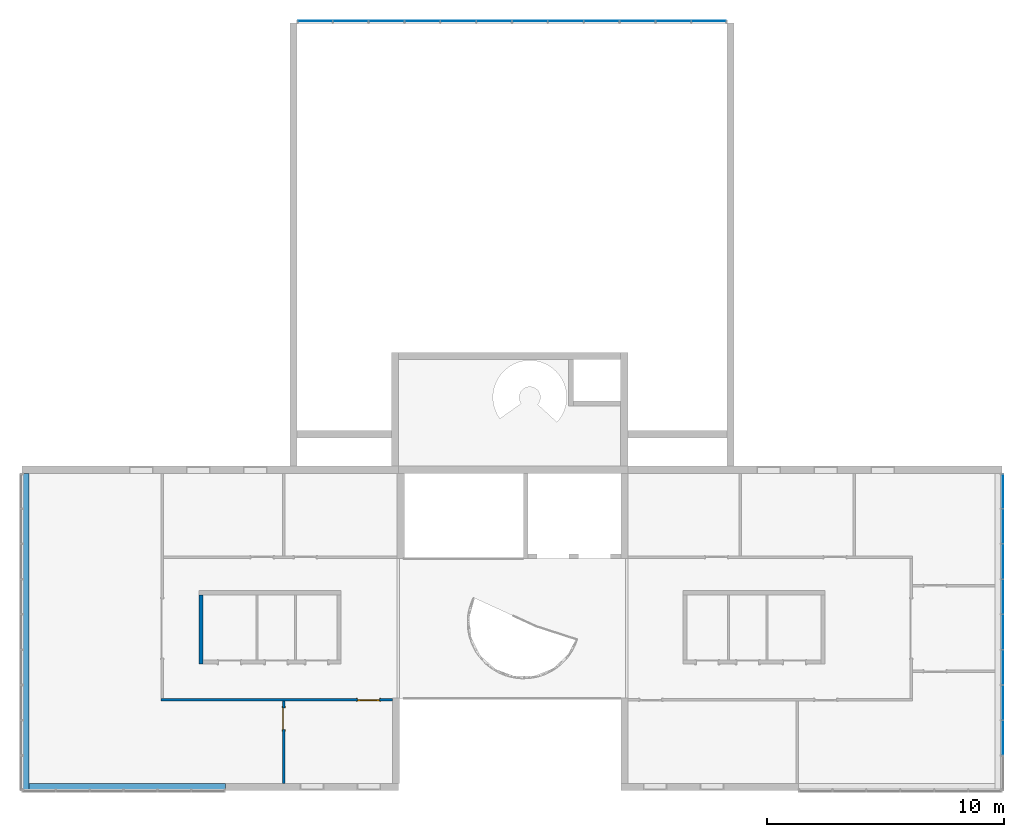
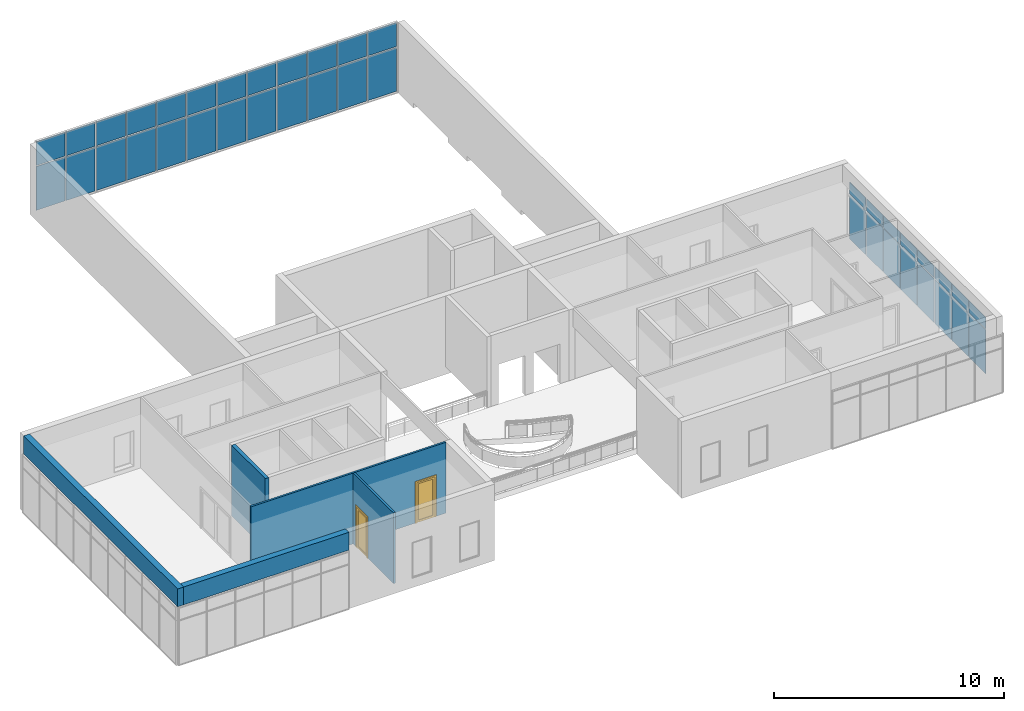
# One storey, part 9 of 13: 40 plates, 5 walls, 2 doors, 2 openings, 2 elements without a shape of their own.
"""IFC2X3 building model written with IfcOpenShell, lengths in millimetres."""

import ifcopenshell
import ifcopenshell.guid

model = None  # the IFC model being written
_history = None  # IfcOwnerHistory: only IFC2X3 demands one
_inside = {}  # id of a spatial element -> (the spatial element, [elements in it])
_under = {}  # id of a project, library or spatial element -> (it, [spatial elements below it])
_declared = {}  # id of a project -> (the project, [libraries it declares])
_typed = {}  # id of a type object -> (the type object, [elements of that type])
_made_of = {}  # id of a material, layer set ... -> (it, [elements and type objects made of it])


def new_model(schema):
    """Start an empty IFC model of exactly this schema.

    Asked for "IFC4X3", IfcOpenShell would pick the latest addendum, in which some entities
    have other attributes; the version numbers below select the first issue.
    IFC2X3 requires an IfcOwnerHistory on every rooted entity: one is made here for all.
    """
    global model, _history
    if schema == "IFC4X3":
        model = ifcopenshell.file(schema_version=(4, 3, 0, 0))
    else:
        model = ifcopenshell.file(schema=schema)
    _inside.clear()
    _under.clear()
    _declared.clear()
    _typed.clear()
    _made_of.clear()
    _history = None
    if model.schema == "IFC2X3":
        org = make("IfcOrganization", Name="unknown")
        user = make(
            "IfcPersonAndOrganization",
            ThePerson=make("IfcPerson", FamilyName="unknown"),
            TheOrganization=org,
        )
        app = make(
            "IfcApplication",
            ApplicationDeveloper=org,
            Version="unknown",
            ApplicationFullName="unknown",
            ApplicationIdentifier="unknown",
        )
        _history = make(
            "IfcOwnerHistory",
            OwningUser=user,
            OwningApplication=app,
            ChangeAction="ADDED",
            CreationDate=0,
        )
    return model


def make(cls, **values):
    """One entity of the class cls with the attributes given. An attribute that is None is left unset."""
    return model.create_entity(
        cls, **{name: value for name, value in values.items() if value is not None}
    )


def entity(cls, *values):
    """Any entity or typed value of the class cls, its attributes in the order of the schema. None: left unset."""
    e = model.create_entity(cls)
    for i, value in enumerate(values):
        if value is not None:
            e[i] = value
    return e


def rooted(cls, **values):
    """An entity with a GlobalId (a new one), such as an element, a storey or a relation."""
    return make(cls, GlobalId=ifcopenshell.guid.new(), OwnerHistory=_history, **values)


def si_unit(unit_type, name, prefix=None):
    """IfcSIUnit, for example si_unit("LENGTHUNIT", "METRE", prefix="MILLI")."""
    return make("IfcSIUnit", UnitType=unit_type, Prefix=prefix, Name=name)


def converted_unit(unit_type, name, factor, base, dimensions=None, offset=None):
    """IfcConversionBasedUnit, such as the inch: factor (a typed value) times the base unit."""
    return make(
        "IfcConversionBasedUnit"
        if offset is None
        else "IfcConversionBasedUnitWithOffset",
        ConversionOffset=offset,
        Dimensions=None
        if dimensions is None
        else entity("IfcDimensionalExponents", *dimensions),
        UnitType=unit_type,
        Name=name,
        ConversionFactor=make(
            "IfcMeasureWithUnit", ValueComponent=factor, UnitComponent=base
        ),
    )


def derived_unit(unit_type, elements):
    """IfcDerivedUnit: a product of units, each with its exponent."""
    return make(
        "IfcDerivedUnit",
        Elements=[
            make("IfcDerivedUnitElement", Unit=unit, Exponent=power)
            for unit, power in elements
        ],
        UnitType=unit_type,
    )


def assignment(units):
    """IfcUnitAssignment: the units of a project."""
    return None if units is None else make("IfcUnitAssignment", Units=units)


def point(xyz):
    """IfcCartesianPoint."""
    return None if xyz is None else make("IfcCartesianPoint", Coordinates=xyz)


def direction(xyz):
    """IfcDirection."""
    return None if xyz is None else make("IfcDirection", DirectionRatios=xyz)


def frame(location, z_axis=None, x_axis=None):
    """IfcAxis2Placement3D, a coordinate frame: its origin and axes. An axis left out is left unset."""
    return make(
        "IfcAxis2Placement3D",
        Location=point(location),
        Axis=direction(z_axis),
        RefDirection=direction(x_axis),
    )


def frame_2d(location, x_axis=None):
    """IfcAxis2Placement2D, a coordinate frame in the plane: its origin and x axis."""
    return make(
        "IfcAxis2Placement2D", Location=point(location), RefDirection=direction(x_axis)
    )


def origin():
    """The frame at (0, 0, 0) with its axes left unset."""
    return frame((0.0, 0.0, 0.0))


def origin_2d_with_axis():
    """The frame at (0, 0) in the plane with the x axis (1, 0) written out."""
    return frame_2d((0.0, 0.0), x_axis=(1.0, 0.0))


def place(relative_to, where):
    """IfcLocalPlacement: puts the frame where relative to a parent placement (None: the world)."""
    return make(
        "IfcLocalPlacement", PlacementRelTo=relative_to, RelativePlacement=where
    )


def context(
    kind, dimensions, precision=None, world=None, true_north=None, identifier=None
):
    """IfcGeometricRepresentationContext, for example the 3D "Model" context."""
    return make(
        "IfcGeometricRepresentationContext",
        ContextIdentifier=identifier,
        ContextType=kind,
        CoordinateSpaceDimension=dimensions,
        Precision=precision,
        WorldCoordinateSystem=world,
        TrueNorth=true_north,
    )


def subcontext(parent, identifier, kind, view, scale=None):
    """IfcGeometricRepresentationSubContext, for example "Body" below "Model"."""
    return make(
        "IfcGeometricRepresentationSubContext",
        ContextIdentifier=identifier,
        ContextType=kind,
        ParentContext=parent,
        TargetScale=scale,
        TargetView=view,
    )


def project(units=None, contexts=None):
    """IfcProject with its units and contexts."""
    return rooted(
        "IfcProject",
        Name="project",
        RepresentationContexts=contexts,
        UnitsInContext=assignment(units),
    )


def spatial(cls, under=None, at=None, **own):
    """A site, building, storey or space (cls), placed at a placement, below another one or the project."""
    s = rooted(cls, ObjectPlacement=at, **own)
    if under is not None:
        _under.setdefault(under.id(), (under, []))[1].append(s)
    return s


def polyline(points):
    """IfcPolyline through the points."""
    return make("IfcPolyline", Points=[point(p) for p in points])


def profile(cls, at=None, kind="AREA", **sizes):
    """A parametric profile (cls). Its sizes go by their IFC names, for example OverallWidth=200.0."""
    return make(cls, ProfileType=kind, Position=at, **sizes)


def rectangle(**sizes):
    """IfcRectangleProfileDef."""
    return profile("IfcRectangleProfileDef", **sizes)


def outline(outer, holes=None, kind="AREA"):
    """IfcArbitraryClosedProfileDef: a profile drawn as a closed curve; with holes, ...WithVoids."""
    if holes is None:
        return make("IfcArbitraryClosedProfileDef", ProfileType=kind, OuterCurve=outer)
    return make(
        "IfcArbitraryProfileDefWithVoids",
        ProfileType=kind,
        OuterCurve=outer,
        InnerCurves=holes,
    )


def extrude(swept, where, along, depth):
    """IfcExtrudedAreaSolid: the profile swept, set in the frame where, extruded along a direction by depth."""
    return make(
        "IfcExtrudedAreaSolid",
        SweptArea=swept,
        Position=where,
        ExtrudedDirection=direction(along),
        Depth=depth,
    )


def shape(context_of_items, identifier, shape_type, items):
    """IfcShapeRepresentation: the items that make up one representation, for example the "Body"."""
    return make(
        "IfcShapeRepresentation",
        ContextOfItems=context_of_items,
        RepresentationIdentifier=identifier,
        RepresentationType=shape_type,
        Items=items,
    )


def source(mapping_origin, context_of_items, identifier, shape_type, items):
    """IfcRepresentationMap: a shape defined once, which mapped items show again and again."""
    return make(
        "IfcRepresentationMap",
        MappingOrigin=mapping_origin,
        MappedRepresentation=shape(context_of_items, identifier, shape_type, items),
    )


def transform(
    local_origin,
    x_axis=None,
    y_axis=None,
    z_axis=None,
    scale=None,
    scale2=None,
    scale3=None,
    uniform=True,
):
    """IfcCartesianTransformationOperator3D, or its non-uniform kind. x_axis, y_axis, z_axis: its Axis1, 2, 3."""
    if uniform:
        return make(
            "IfcCartesianTransformationOperator3D",
            Axis1=direction(x_axis),
            Axis2=direction(y_axis),
            LocalOrigin=point(local_origin),
            Scale=scale,
            Axis3=direction(z_axis),
        )
    return make(
        "IfcCartesianTransformationOperator3DnonUniform",
        Axis1=direction(x_axis),
        Axis2=direction(y_axis),
        LocalOrigin=point(local_origin),
        Scale=scale,
        Axis3=direction(z_axis),
        Scale2=scale2,
        Scale3=scale3,
    )


def mapped(mapping_source, mapping_target):
    """IfcMappedItem: shows the shape of a source again, moved by a transform."""
    return make(
        "IfcMappedItem", MappingSource=mapping_source, MappingTarget=mapping_target
    )


def material(Name=None, Category=None):
    """IfcMaterial."""
    return make("IfcMaterial", Name=Name, Category=Category)


def material_list(materials):
    """IfcMaterialList."""
    return make("IfcMaterialList", Materials=materials)


def layer(
    of_material, thickness, ventilated=None, Name=None, Category=None, Priority=None
):
    """IfcMaterialLayer: one layer of a wall or slab, of a material (None: an air gap)."""
    return make(
        "IfcMaterialLayer",
        Material=of_material,
        LayerThickness=thickness,
        IsVentilated=ventilated,
        Name=Name,
        Category=Category,
        Priority=Priority,
    )


def layer_set(layers, Name=None):
    """IfcMaterialLayerSet."""
    return make("IfcMaterialLayerSet", MaterialLayers=layers, LayerSetName=Name)


def layer_usage(for_layer_set, set_direction, sense, offset, extent=None):
    """IfcMaterialLayerSetUsage: how a layer set lies in its element."""
    return make(
        "IfcMaterialLayerSetUsage",
        ForLayerSet=for_layer_set,
        LayerSetDirection=set_direction,
        DirectionSense=sense,
        OffsetFromReferenceLine=offset,
        ReferenceExtent=extent,
    )


def made_of(thing, what):
    """Note that an element or type object is made of a material, layer set ...; save() writes the relation."""
    if what is not None:
        _made_of.setdefault(what.id(), (what, []))[1].append(thing)
    return thing


def type_object(cls, material=None, **own):
    """A type object (cls), such as IfcWallType, which elements share."""
    return made_of(rooted(cls, **own), material)


def type_shapes(of_type, sources):
    """Give a type object the sources (RepresentationMaps) that its elements show as mapped items."""
    of_type.RepresentationMaps = sources


def element(
    cls,
    number,
    at=None,
    inside=None,
    cuts=None,
    type_object=None,
    material=None,
    context=None,
    identifier="Body",
    shape_type=None,
    held_by="IfcProductDefinitionShape",
    body=None,
    shapes=None,
    **own,
):
    """One element of the class cls, such as IfcWall. Its Tag is "e" and its number.

    at: its placement. inside: the storey or other place that contains it. cuts: it is an
    opening in that element (IfcRelVoidsElement). A single representation is given by context,
    identifier, shape_type and body (its items); several are given by shapes. held_by: the class
    of the entity that holds the representations. save() writes the other relations.
    """
    e = rooted(cls, Tag="e%d" % number, ObjectPlacement=at, **own)
    if body is not None:
        shapes = [shape(context, identifier, shape_type, body)]
    if shapes is not None:
        e.Representation = make(held_by, Representations=shapes)
    if inside is not None:
        _inside.setdefault(inside.id(), (inside, []))[1].append(e)
    if cuts is not None:
        rooted(
            "IfcRelVoidsElement", RelatingBuildingElement=cuts, RelatedOpeningElement=e
        )
    if type_object is not None:
        _typed.setdefault(type_object.id(), (type_object, []))[1].append(e)
    return made_of(e, material)


def fill(opening, filler):
    """IfcRelFillsElement: the door or window that sits in an opening."""
    return rooted(
        "IfcRelFillsElement",
        RelatingOpeningElement=opening,
        RelatedBuildingElement=filler,
    )


def aggregate(whole, parts):
    """IfcRelAggregates: a whole, such as a stair, and the parts it consists of."""
    return rooted("IfcRelAggregates", RelatingObject=whole, RelatedObjects=parts)


def save(model, path):
    """Write the relations noted so far, then the file.

    IfcRelAggregates (storeys below a building ...), IfcRelContainedInSpatialStructure (elements
    in a storey), IfcRelDefinesByType, IfcRelAssociatesMaterial and IfcRelDeclares: one each for
    every whole, place, type object, material and project.
    """
    for whole, parts in _under.values():
        aggregate(whole, parts)
    for where, things in _inside.values():
        rooted(
            "IfcRelContainedInSpatialStructure",
            RelatedElements=things,
            RelatingStructure=where,
        )
    for kind, things in _typed.values():
        rooted("IfcRelDefinesByType", RelatedObjects=things, RelatingType=kind)
    for what, things in _made_of.values():
        rooted("IfcRelAssociatesMaterial", RelatedObjects=things, RelatingMaterial=what)
    for by, libraries in _declared.values():
        rooted("IfcRelDeclares", RelatingContext=by, RelatedDefinitions=libraries)
    model.write(path)


model = new_model("IFC2X3")

# Units and contexts
model_context = context("Model", 3, precision=0.01, world=origin(), true_north=direction((6.12303176911189e-17, 1.0)))
context_of_model = context(None, 3, precision=0.01, world=origin(), true_north=direction((6.12303176911189e-17, 1.0)))
body_context = subcontext(model_context, "Body", "Model", "MODEL_VIEW")
ifc_project = project(units=[si_unit("LENGTHUNIT", "METRE", prefix="MILLI"), si_unit("AREAUNIT", "SQUARE_METRE"), si_unit("VOLUMEUNIT", "CUBIC_METRE"), converted_unit("PLANEANGLEUNIT", "DEGREE", entity("IfcRatioMeasure", 0.0174532925199433), si_unit("PLANEANGLEUNIT", "RADIAN"), dimensions=[0, 0, 0, 0, 0, 0, 0]), si_unit("MASSUNIT", "GRAM", prefix="KILO"), si_unit("TIMEUNIT", "SECOND"), si_unit("FREQUENCYUNIT", "HERTZ"), si_unit("THERMODYNAMICTEMPERATUREUNIT", "DEGREE_CELSIUS"), derived_unit("THERMALTRANSMITTANCEUNIT", [(si_unit("MASSUNIT", "GRAM", prefix="KILO"), 1), (si_unit("THERMODYNAMICTEMPERATUREUNIT", "KELVIN"), -1), (si_unit("TIMEUNIT", "SECOND"), -3)]), derived_unit("VOLUMETRICFLOWRATEUNIT", [(si_unit("LENGTHUNIT", "METRE"), 3), (si_unit("TIMEUNIT", "SECOND"), -1)]), si_unit("ELECTRICCURRENTUNIT", "AMPERE"), si_unit("ELECTRICVOLTAGEUNIT", "VOLT"), si_unit("POWERUNIT", "WATT"), si_unit("FORCEUNIT", "NEWTON", prefix="KILO"), si_unit("ILLUMINANCEUNIT", "LUX"), si_unit("LUMINOUSFLUXUNIT", "LUMEN"), si_unit("LUMINOUSINTENSITYUNIT", "CANDELA"), si_unit("PRESSUREUNIT", "PASCAL")], contexts=[model_context, context_of_model])

# Site, building, storey
site_placement = place(None, origin())
site = spatial("IfcSite", under=ifc_project, at=site_placement, CompositionType="ELEMENT")
building_placement = place(site_placement, origin())
building = spatial("IfcBuilding", under=site, at=building_placement, CompositionType="ELEMENT")
storey_placement = place(building_placement, frame((0.0, 0.0, 3750.0)))
storey = spatial("IfcBuildingStorey", under=building, at=storey_placement, Name="02. 2 etg.", CompositionType="ELEMENT", Elevation=3750.00000000068)

# Curtain wall, plates
curtain_wall_type = type_object("IfcCurtainWallType", Name="Curtain Wall:Storefront", PredefinedType="NOTDEFINED")
curtain_wall_1_placement = place(storey_placement, frame((0.0, 0.0, -3750.0)))
curtain_wall_1 = element("IfcCurtainWall", 1, at=curtain_wall_1_placement, inside=storey, type_object=curtain_wall_type, Name="Curtain Wall:Storefront", ObjectType="Curtain Wall:Storefront")
ifc_material_1 = material(Name="Glass")
plate_type_1 = type_object("IfcPlateType", Name="Glazed", PredefinedType="CURTAIN_PANEL", material=ifc_material_1)
shared_shape_1 = source(origin(), body_context, "Body", "SweptSolid", [
    extrude(rectangle(XDim=25.0, YDim=1436.66666666667, at=origin_2d_with_axis()), frame((718.333333333334, 12.5, 0.0), z_axis=(0.0, 0.0, 1.0), x_axis=(0.0, 1.0, 0.0)), (0.0, 0.0, 1.0), 2325.0),
])
type_shapes(plate_type_1, [shared_shape_1])
plate_1_placement = place(curtain_wall_1_placement, frame((11409.1178561748, 19004.5, 3800.0)))
plate_1 = element("IfcPlate", 2, at=plate_1_placement, type_object=plate_type_1, material=ifc_material_1, Name="System Panel:Glazed", ObjectType="Glazed", context=body_context, shape_type="MappedRepresentation", body=[
    mapped(shared_shape_1, transform((0.0, 0.0, 0.0), scale=1.0)),
])
plate_2_placement = place(curtain_wall_1_placement, frame((28012.4511895081, 19004.5, 3800.0)))
plate_2 = element("IfcPlate", 3, at=plate_2_placement, type_object=plate_type_1, material=ifc_material_1, Name="System Panel:Glazed", ObjectType="Glazed", context=body_context, shape_type="MappedRepresentation", body=[
    mapped(shared_shape_1, transform((0.0, 0.0, 0.0), scale=1.0)),
])

curtain_wall_2_placement = place(storey_placement, frame((0.0, 0.0, -3750.0)))
curtain_wall_2 = element("IfcCurtainWall", 4, at=curtain_wall_2_placement, inside=storey, type_object=curtain_wall_type, Name="Curtain Wall:Storefront", ObjectType="Curtain Wall:Storefront")
plate_3_placement = place(curtain_wall_2_placement, frame((41122.7357123495, -1571.66666666667, 3500.0), z_axis=(0.0, 0.0, 1.0), x_axis=(0.0, -1.0, 0.0)))
plate_3 = element("IfcPlate", 5, at=plate_3_placement, type_object=plate_type_1, material=ifc_material_1, Name="System Panel:Glazed", ObjectType="Glazed", context=body_context, shape_type="MappedRepresentation", body=[
    mapped(shared_shape_1, transform((0.0, 0.0, 0.0), scale=1.0)),
])
plate_4_placement = place(curtain_wall_2_placement, frame((41122.7357123495, -3058.33333333333, 3500.0), z_axis=(0.0, 0.0, 1.0), x_axis=(0.0, -1.0, 0.0)))
plate_4 = element("IfcPlate", 6, at=plate_4_placement, type_object=plate_type_1, material=ifc_material_1, Name="System Panel:Glazed", ObjectType="Glazed", context=body_context, shape_type="MappedRepresentation", body=[
    mapped(shared_shape_1, transform((0.0, 0.0, 0.0), scale=1.0)),
])
plate_5_placement = place(curtain_wall_2_placement, frame((41122.7357123495, -4545.0, 3500.0), z_axis=(0.0, 0.0, 1.0), x_axis=(0.0, -1.0, 0.0)))
plate_5 = element("IfcPlate", 7, at=plate_5_placement, type_object=plate_type_1, material=ifc_material_1, Name="System Panel:Glazed", ObjectType="Glazed", context=body_context, shape_type="MappedRepresentation", body=[
    mapped(shared_shape_1, transform((0.0, 0.0, 0.0), scale=1.0)),
])
plate_6_placement = place(curtain_wall_2_placement, frame((41122.7357123495, -6031.66666666667, 3500.0), z_axis=(0.0, 0.0, 1.0), x_axis=(0.0, -1.0, 0.0)))
plate_6 = element("IfcPlate", 8, at=plate_6_placement, type_object=plate_type_1, material=ifc_material_1, Name="System Panel:Glazed", ObjectType="Glazed", context=body_context, shape_type="MappedRepresentation", body=[
    mapped(shared_shape_1, transform((0.0, 0.0, 0.0), scale=1.0)),
])
plate_7_placement = place(curtain_wall_2_placement, frame((41122.7357123495, -7518.33333333333, 3500.0), z_axis=(0.0, 0.0, 1.0), x_axis=(0.0, -1.0, 0.0)))
plate_7 = element("IfcPlate", 9, at=plate_7_placement, type_object=plate_type_1, material=ifc_material_1, Name="System Panel:Glazed", ObjectType="Glazed", context=body_context, shape_type="MappedRepresentation", body=[
    mapped(shared_shape_1, transform((0.0, 0.0, 0.0), scale=1.0)),
])
plate_8_placement = place(curtain_wall_2_placement, frame((41122.7357123495, -9005.0, 3500.0), z_axis=(0.0, 0.0, 1.0), x_axis=(0.0, -1.0, 0.0)))
plate_8 = element("IfcPlate", 10, at=plate_8_placement, type_object=plate_type_1, material=ifc_material_1, Name="System Panel:Glazed", ObjectType="Glazed", context=body_context, shape_type="MappedRepresentation", body=[
    mapped(shared_shape_1, transform((0.0, 0.0, 0.0), scale=1.0)),
])
plate_9_placement = place(curtain_wall_2_placement, frame((41122.7357123495, -10491.6666666667, 3500.0), z_axis=(0.0, 0.0, 1.0), x_axis=(0.0, -1.0, 0.0)))
plate_9 = element("IfcPlate", 11, at=plate_9_placement, type_object=plate_type_1, material=ifc_material_1, Name="System Panel:Glazed", ObjectType="Glazed", context=body_context, shape_type="MappedRepresentation", body=[
    mapped(shared_shape_1, transform((0.0, 0.0, 0.0), scale=1.0)),
])

# Plate
plate_type_2 = type_object("IfcPlateType", Name="Glazed", PredefinedType="CURTAIN_PANEL", material=ifc_material_1)
shared_shape_2 = source(origin(), body_context, "Body", "SweptSolid", [
    extrude(rectangle(XDim=25.0, YDim=1461.66666666666, at=origin_2d_with_axis()), frame((730.833333333332, 12.5, 0.0), z_axis=(0.0, 0.0, 1.0), x_axis=(0.0, 1.0, 0.0)), (0.0, 0.0, 1.0), 2325.0),
])
type_shapes(plate_type_2, [shared_shape_2])
plate_10_placement = place(curtain_wall_1_placement, frame((12895.7845228415, 19004.5, 3800.0)))
plate_10 = element("IfcPlate", 12, at=plate_10_placement, type_object=plate_type_2, material=ifc_material_1, Name="System Panel:Glazed", ObjectType="Glazed", context=body_context, shape_type="MappedRepresentation", body=[
    mapped(shared_shape_2, transform((0.0, 0.0, 0.0), scale=1.0)),
])

plate_11_placement = place(curtain_wall_1_placement, frame((14407.4511895081, 19004.5, 3800.0)))
plate_11 = element("IfcPlate", 13, at=plate_11_placement, type_object=plate_type_2, material=ifc_material_1, Name="System Panel:Glazed", ObjectType="Glazed", context=body_context, shape_type="MappedRepresentation", body=[
    mapped(shared_shape_2, transform((0.0, 0.0, 0.0), scale=1.0)),
])

plate_12_placement = place(curtain_wall_1_placement, frame((15919.1178561748, 19004.5, 3800.0)))
plate_12 = element("IfcPlate", 14, at=plate_12_placement, type_object=plate_type_2, material=ifc_material_1, Name="System Panel:Glazed", ObjectType="Glazed", context=body_context, shape_type="MappedRepresentation", body=[
    mapped(shared_shape_2, transform((0.0, 0.0, 0.0), scale=1.0)),
])

plate_13_placement = place(curtain_wall_1_placement, frame((17430.7845228414, 19004.5, 3800.0)))
plate_13 = element("IfcPlate", 15, at=plate_13_placement, type_object=plate_type_2, material=ifc_material_1, Name="System Panel:Glazed", ObjectType="Glazed", context=body_context, shape_type="MappedRepresentation", body=[
    mapped(shared_shape_2, transform((0.0, 0.0, 0.0), scale=1.0)),
])

plate_14_placement = place(curtain_wall_1_placement, frame((18942.4511895081, 19004.5, 3800.0)))
plate_14 = element("IfcPlate", 16, at=plate_14_placement, type_object=plate_type_2, material=ifc_material_1, Name="System Panel:Glazed", ObjectType="Glazed", context=body_context, shape_type="MappedRepresentation", body=[
    mapped(shared_shape_2, transform((0.0, 0.0, 0.0), scale=1.0)),
])

plate_15_placement = place(curtain_wall_1_placement, frame((20454.1178561748, 19004.5, 3800.0)))
plate_15 = element("IfcPlate", 17, at=plate_15_placement, type_object=plate_type_2, material=ifc_material_1, Name="System Panel:Glazed", ObjectType="Glazed", context=body_context, shape_type="MappedRepresentation", body=[
    mapped(shared_shape_2, transform((0.0, 0.0, 0.0), scale=1.0)),
])

plate_16_placement = place(curtain_wall_1_placement, frame((21965.7845228414, 19004.5, 3800.0)))
plate_16 = element("IfcPlate", 18, at=plate_16_placement, type_object=plate_type_2, material=ifc_material_1, Name="System Panel:Glazed", ObjectType="Glazed", context=body_context, shape_type="MappedRepresentation", body=[
    mapped(shared_shape_2, transform((0.0, 0.0, 0.0), scale=1.0)),
])

plate_17_placement = place(curtain_wall_1_placement, frame((23477.4511895081, 19004.5, 3800.0)))
plate_17 = element("IfcPlate", 19, at=plate_17_placement, type_object=plate_type_2, material=ifc_material_1, Name="System Panel:Glazed", ObjectType="Glazed", context=body_context, shape_type="MappedRepresentation", body=[
    mapped(shared_shape_2, transform((0.0, 0.0, 0.0), scale=1.0)),
])

plate_18_placement = place(curtain_wall_1_placement, frame((24989.1178561748, 19004.5, 3800.0)))
plate_18 = element("IfcPlate", 20, at=plate_18_placement, type_object=plate_type_2, material=ifc_material_1, Name="System Panel:Glazed", ObjectType="Glazed", context=body_context, shape_type="MappedRepresentation", body=[
    mapped(shared_shape_2, transform((0.0, 0.0, 0.0), scale=1.0)),
])

plate_19_placement = place(curtain_wall_1_placement, frame((26500.7845228414, 19004.5, 3800.0)))
plate_19 = element("IfcPlate", 21, at=plate_19_placement, type_object=plate_type_2, material=ifc_material_1, Name="System Panel:Glazed", ObjectType="Glazed", context=body_context, shape_type="MappedRepresentation", body=[
    mapped(shared_shape_2, transform((0.0, 0.0, 0.0), scale=1.0)),
])

plate_type_3 = type_object("IfcPlateType", Name="Glazed", PredefinedType="CURTAIN_PANEL", material=ifc_material_1)
shared_shape_3 = source(origin(), body_context, "Body", "SweptSolid", [
    extrude(rectangle(XDim=25.0, YDim=1436.66666666666, at=origin_2d_with_axis()), frame((718.333333333332, 12.5, 0.0), z_axis=(0.0, 0.0, 1.0), x_axis=(0.0, 1.0, 0.0)), (0.0, 0.0, 1.0), 1274.99999999993),
])
type_shapes(plate_type_3, [shared_shape_3])
plate_20_placement = place(curtain_wall_1_placement, frame((11409.1178561748, 19004.5, 6175.0)))
plate_20 = element("IfcPlate", 22, at=plate_20_placement, type_object=plate_type_3, material=ifc_material_1, Name="System Panel:Glazed", ObjectType="Glazed", context=body_context, shape_type="MappedRepresentation", body=[
    mapped(shared_shape_3, transform((0.0, 0.0, 0.0), scale=1.0)),
])

plate_21_placement = place(curtain_wall_1_placement, frame((28012.4511895081, 19004.5, 6175.0)))
plate_21 = element("IfcPlate", 23, at=plate_21_placement, type_object=plate_type_3, material=ifc_material_1, Name="System Panel:Glazed", ObjectType="Glazed", context=body_context, shape_type="MappedRepresentation", body=[
    mapped(shared_shape_3, transform((0.0, 0.0, 0.0), scale=1.0)),
])

plate_type_4 = type_object("IfcPlateType", Name="Glazed", PredefinedType="CURTAIN_PANEL", material=ifc_material_1)
shared_shape_4 = source(origin(), body_context, "Body", "SweptSolid", [
    extrude(rectangle(XDim=25.0, YDim=1461.66666666666, at=origin_2d_with_axis()), frame((730.833333333332, 12.5, 0.0), z_axis=(0.0, 0.0, 1.0), x_axis=(0.0, 1.0, 0.0)), (0.0, 0.0, 1.0), 1274.99999999993),
])
type_shapes(plate_type_4, [shared_shape_4])
plate_22_placement = place(curtain_wall_1_placement, frame((12895.7845228415, 19004.5, 6175.0)))
plate_22 = element("IfcPlate", 24, at=plate_22_placement, type_object=plate_type_4, material=ifc_material_1, Name="System Panel:Glazed", ObjectType="Glazed", context=body_context, shape_type="MappedRepresentation", body=[
    mapped(shared_shape_4, transform((0.0, 0.0, 0.0), scale=1.0)),
])

plate_23_placement = place(curtain_wall_1_placement, frame((14407.4511895081, 19004.5, 6175.0)))
plate_23 = element("IfcPlate", 25, at=plate_23_placement, type_object=plate_type_4, material=ifc_material_1, Name="System Panel:Glazed", ObjectType="Glazed", context=body_context, shape_type="MappedRepresentation", body=[
    mapped(shared_shape_4, transform((0.0, 0.0, 0.0), scale=1.0)),
])

plate_24_placement = place(curtain_wall_1_placement, frame((15919.1178561748, 19004.5, 6175.0)))
plate_24 = element("IfcPlate", 26, at=plate_24_placement, type_object=plate_type_4, material=ifc_material_1, Name="System Panel:Glazed", ObjectType="Glazed", context=body_context, shape_type="MappedRepresentation", body=[
    mapped(shared_shape_4, transform((0.0, 0.0, 0.0), scale=1.0)),
])

plate_25_placement = place(curtain_wall_1_placement, frame((17430.7845228414, 19004.5, 6175.0)))
plate_25 = element("IfcPlate", 27, at=plate_25_placement, type_object=plate_type_4, material=ifc_material_1, Name="System Panel:Glazed", ObjectType="Glazed", context=body_context, shape_type="MappedRepresentation", body=[
    mapped(shared_shape_4, transform((0.0, 0.0, 0.0), scale=1.0)),
])

plate_26_placement = place(curtain_wall_1_placement, frame((18942.4511895081, 19004.5, 6175.0)))
plate_26 = element("IfcPlate", 28, at=plate_26_placement, type_object=plate_type_4, material=ifc_material_1, Name="System Panel:Glazed", ObjectType="Glazed", context=body_context, shape_type="MappedRepresentation", body=[
    mapped(shared_shape_4, transform((0.0, 0.0, 0.0), scale=1.0)),
])

plate_27_placement = place(curtain_wall_1_placement, frame((20454.1178561748, 19004.5, 6175.0)))
plate_27 = element("IfcPlate", 29, at=plate_27_placement, type_object=plate_type_4, material=ifc_material_1, Name="System Panel:Glazed", ObjectType="Glazed", context=body_context, shape_type="MappedRepresentation", body=[
    mapped(shared_shape_4, transform((0.0, 0.0, 0.0), scale=1.0)),
])

plate_28_placement = place(curtain_wall_1_placement, frame((21965.7845228414, 19004.5, 6175.0)))
plate_28 = element("IfcPlate", 30, at=plate_28_placement, type_object=plate_type_4, material=ifc_material_1, Name="System Panel:Glazed", ObjectType="Glazed", context=body_context, shape_type="MappedRepresentation", body=[
    mapped(shared_shape_4, transform((0.0, 0.0, 0.0), scale=1.0)),
])

plate_29_placement = place(curtain_wall_1_placement, frame((23477.4511895081, 19004.5, 6175.0)))
plate_29 = element("IfcPlate", 31, at=plate_29_placement, type_object=plate_type_4, material=ifc_material_1, Name="System Panel:Glazed", ObjectType="Glazed", context=body_context, shape_type="MappedRepresentation", body=[
    mapped(shared_shape_4, transform((0.0, 0.0, 0.0), scale=1.0)),
])

plate_30_placement = place(curtain_wall_1_placement, frame((24989.1178561748, 19004.5, 6175.0)))
plate_30 = element("IfcPlate", 32, at=plate_30_placement, type_object=plate_type_4, material=ifc_material_1, Name="System Panel:Glazed", ObjectType="Glazed", context=body_context, shape_type="MappedRepresentation", body=[
    mapped(shared_shape_4, transform((0.0, 0.0, 0.0), scale=1.0)),
])

plate_31_placement = place(curtain_wall_1_placement, frame((26500.7845228414, 19004.5, 6175.0)))
plate_31 = element("IfcPlate", 33, at=plate_31_placement, type_object=plate_type_4, material=ifc_material_1, Name="System Panel:Glazed", ObjectType="Glazed", context=body_context, shape_type="MappedRepresentation", body=[
    mapped(shared_shape_4, transform((0.0, 0.0, 0.0), scale=1.0)),
])

aggregate(curtain_wall_1, [plate_1, plate_10, plate_11, plate_12, plate_13, plate_14, plate_15, plate_16, plate_17, plate_18, plate_19, plate_2, plate_20, plate_22, plate_23, plate_24, plate_25, plate_26, plate_27, plate_28, plate_29, plate_30, plate_31, plate_21])

plate_type_5 = type_object("IfcPlateType", Name="Glazed", PredefinedType="CURTAIN_PANEL", material=ifc_material_1)
shared_shape_5 = source(origin(), body_context, "Body", "SweptSolid", [
    extrude(rectangle(XDim=25.0, YDim=1411.66666666667, at=origin_2d_with_axis()), frame((705.833333333333, 12.5, 0.0), z_axis=(0.0, 0.0, 1.0), x_axis=(0.0, 1.0, 0.0)), (0.0, 0.0, 1.0), 2325.0),
])
type_shapes(plate_type_5, [shared_shape_5])
plate_32_placement = place(curtain_wall_2_placement, frame((41122.7357123495, -110.0, 3500.0), z_axis=(0.0, 0.0, 1.0), x_axis=(0.0, -1.0, 0.0)))
plate_32 = element("IfcPlate", 34, at=plate_32_placement, type_object=plate_type_5, material=ifc_material_1, Name="System Panel:Glazed", ObjectType="Glazed", context=body_context, shape_type="MappedRepresentation", body=[
    mapped(shared_shape_5, transform((0.0, 0.0, 0.0), scale=1.0)),
])

plate_type_6 = type_object("IfcPlateType", Name="Glazed", PredefinedType="CURTAIN_PANEL", material=ifc_material_1)
shared_shape_6 = source(origin(), body_context, "Body", "SweptSolid", [
    extrude(rectangle(XDim=25.0, YDim=1411.66666666667, at=origin_2d_with_axis()), frame((705.833333333333, 12.5, 0.0), z_axis=(0.0, 0.0, 1.0), x_axis=(0.0, 1.0, 0.0)), (0.0, 0.0, 1.0), 625.000000000002),
])
type_shapes(plate_type_6, [shared_shape_6])
plate_33_placement = place(curtain_wall_2_placement, frame((41122.7357123495, -110.0, 5875.0), z_axis=(0.0, 0.0, 1.0), x_axis=(0.0, -1.0, 0.0)))
plate_33 = element("IfcPlate", 35, at=plate_33_placement, type_object=plate_type_6, material=ifc_material_1, Name="System Panel:Glazed", ObjectType="Glazed", context=body_context, shape_type="MappedRepresentation", body=[
    mapped(shared_shape_6, transform((0.0, 0.0, 0.0), scale=1.0)),
])

plate_type_7 = type_object("IfcPlateType", Name="Glazed", PredefinedType="CURTAIN_PANEL", material=ifc_material_1)
shared_shape_7 = source(origin(), body_context, "Body", "SweptSolid", [
    extrude(rectangle(XDim=25.0, YDim=1436.66666666667, at=origin_2d_with_axis()), frame((718.333333333334, 12.5, 0.0), z_axis=(0.0, 0.0, 1.0), x_axis=(0.0, 1.0, 0.0)), (0.0, 0.0, 1.0), 625.000000000002),
])
type_shapes(plate_type_7, [shared_shape_7])
plate_34_placement = place(curtain_wall_2_placement, frame((41122.7357123495, -1571.66666666667, 5875.0), z_axis=(0.0, 0.0, 1.0), x_axis=(0.0, -1.0, 0.0)))
plate_34 = element("IfcPlate", 36, at=plate_34_placement, type_object=plate_type_7, material=ifc_material_1, Name="System Panel:Glazed", ObjectType="Glazed", context=body_context, shape_type="MappedRepresentation", body=[
    mapped(shared_shape_7, transform((0.0, 0.0, 0.0), scale=1.0)),
])

plate_35_placement = place(curtain_wall_2_placement, frame((41122.7357123495, -3058.33333333333, 5875.0), z_axis=(0.0, 0.0, 1.0), x_axis=(0.0, -1.0, 0.0)))
plate_35 = element("IfcPlate", 37, at=plate_35_placement, type_object=plate_type_7, material=ifc_material_1, Name="System Panel:Glazed", ObjectType="Glazed", context=body_context, shape_type="MappedRepresentation", body=[
    mapped(shared_shape_7, transform((0.0, 0.0, 0.0), scale=1.0)),
])

plate_36_placement = place(curtain_wall_2_placement, frame((41122.7357123495, -4545.0, 5875.0), z_axis=(0.0, 0.0, 1.0), x_axis=(0.0, -1.0, 0.0)))
plate_36 = element("IfcPlate", 38, at=plate_36_placement, type_object=plate_type_7, material=ifc_material_1, Name="System Panel:Glazed", ObjectType="Glazed", context=body_context, shape_type="MappedRepresentation", body=[
    mapped(shared_shape_7, transform((0.0, 0.0, 0.0), scale=1.0)),
])

plate_37_placement = place(curtain_wall_2_placement, frame((41122.7357123495, -6031.66666666667, 5875.0), z_axis=(0.0, 0.0, 1.0), x_axis=(0.0, -1.0, 0.0)))
plate_37 = element("IfcPlate", 39, at=plate_37_placement, type_object=plate_type_7, material=ifc_material_1, Name="System Panel:Glazed", ObjectType="Glazed", context=body_context, shape_type="MappedRepresentation", body=[
    mapped(shared_shape_7, transform((0.0, 0.0, 0.0), scale=1.0)),
])

plate_38_placement = place(curtain_wall_2_placement, frame((41122.7357123495, -7518.33333333333, 5875.0), z_axis=(0.0, 0.0, 1.0), x_axis=(0.0, -1.0, 0.0)))
plate_38 = element("IfcPlate", 40, at=plate_38_placement, type_object=plate_type_7, material=ifc_material_1, Name="System Panel:Glazed", ObjectType="Glazed", context=body_context, shape_type="MappedRepresentation", body=[
    mapped(shared_shape_7, transform((0.0, 0.0, 0.0), scale=1.0)),
])

plate_39_placement = place(curtain_wall_2_placement, frame((41122.7357123495, -9005.0, 5875.0), z_axis=(0.0, 0.0, 1.0), x_axis=(0.0, -1.0, 0.0)))
plate_39 = element("IfcPlate", 41, at=plate_39_placement, type_object=plate_type_7, material=ifc_material_1, Name="System Panel:Glazed", ObjectType="Glazed", context=body_context, shape_type="MappedRepresentation", body=[
    mapped(shared_shape_7, transform((0.0, 0.0, 0.0), scale=1.0)),
])

plate_40_placement = place(curtain_wall_2_placement, frame((41122.7357123495, -10491.6666666667, 5875.0), z_axis=(0.0, 0.0, 1.0), x_axis=(0.0, -1.0, 0.0)))
plate_40 = element("IfcPlate", 42, at=plate_40_placement, type_object=plate_type_7, material=ifc_material_1, Name="System Panel:Glazed", ObjectType="Glazed", context=body_context, shape_type="MappedRepresentation", body=[
    mapped(shared_shape_7, transform((0.0, 0.0, 0.0), scale=1.0)),
])

aggregate(curtain_wall_2, [plate_32, plate_3, plate_4, plate_5, plate_6, plate_7, plate_8, plate_9, plate_33, plate_34, plate_35, plate_36, plate_37, plate_38, plate_39, plate_40])

# Walls
ifc_material_2 = material(Name="Brick, Engineering, Soldier Course")
ifc_layer_1 = layer(ifc_material_2, 300.0)
ifc_layer_set_1 = layer_set([ifc_layer_1], Name="Basic Wall:Generic - 300mm")
ifc_layer_usage_1 = layer_usage(ifc_layer_set_1, "AXIS2", "POSITIVE", -150.0)
wall_type_1 = type_object("IfcWallType", Name="Basic Wall:Generic - 300mm", PredefinedType="STANDARD", material=ifc_layer_set_1)
wall_1_placement = place(storey_placement, frame((-90.0, -60.0, 2800.0), z_axis=(0.0, 0.0, 1.0), x_axis=(0.0, -1.0, 0.0)))
element("IfcWallStandardCase", 43, at=wall_1_placement, inside=storey, type_object=wall_type_1, material=ifc_layer_usage_1, Name="Basic Wall:Generic - 300mm", ObjectType="Basic Wall:Generic - 300mm:6291", context=body_context, shape_type="SweptSolid", body=[
    extrude(rectangle(XDim=13380.0000000001, YDim=300.0, at=frame_2d((6690.00000000003, -1.4210854715202e-14), x_axis=(-1.0, 0.0))), origin(), (0.0, 0.0, 1.0), 949.999999999925),
])
ifc_layer_usage_2 = layer_usage(ifc_layer_set_1, "AXIS2", "POSITIVE", -150.0)
wall_2_placement = place(storey_placement, frame((8340.0, -13290.0, 2800.0), z_axis=(0.0, 0.0, 1.0), x_axis=(-1.0, 0.0, 0.0)))
element("IfcWallStandardCase", 44, at=wall_2_placement, inside=storey, type_object=wall_type_1, material=ifc_layer_usage_2, Name="Basic Wall:Generic - 300mm", ObjectType="Basic Wall:Generic - 300mm:6291", context=body_context, shape_type="SweptSolid", body=[
    extrude(rectangle(XDim=8280.00000000003, YDim=300.000000000001, at=frame_2d((4140.00000000001, 1.98951966012828e-13), x_axis=(-1.0, 0.0))), origin(), (0.0, 0.0, 1.0), 949.999999999925),
])

# Wall, opening, door
ifc_material_3 = material(Name="Steel, Paint Finish, Ivory, Matte")
ifc_layer_2 = layer(ifc_material_3, 100.0)
ifc_layer_set_2 = layer_set([ifc_layer_2], Name="Basic Wall:_100mm")
ifc_layer_usage_3 = layer_usage(ifc_layer_set_2, "AXIS2", "NEGATIVE", 50.0)
wall_type_2 = type_object("IfcWallType", Name="Basic Wall:_100mm", PredefinedType="STANDARD", material=ifc_layer_set_2)
wall_3_placement = place(storey_placement, frame((10800.0, -13140.0, 0.0), z_axis=(0.0, 0.0, 1.0), x_axis=(0.0, 1.0, 0.0)))
wall_3 = element("IfcWallStandardCase", 45, at=wall_3_placement, inside=storey, type_object=wall_type_2, material=ifc_layer_usage_3, Name="Basic Wall:_100mm", ObjectType="Basic Wall:_100mm", context=body_context, shape_type="SweptSolid", body=[
    extrude(rectangle(XDim=3490.00000000005, YDim=99.9999999999989, at=frame_2d((1745.00000000002, 0.0), x_axis=(-1.0, 0.0))), origin(), (0.0, 0.0, 1.0), 3750.0),
])
opening_1_placement = place(wall_3_placement, frame((2275.0, -50.0, 0.0)))
opening_1 = element("IfcOpeningElement", 46, at=opening_1_placement, cuts=wall_3, Name="M_Single-Glass 1:0915 x 2134mm:1", ObjectType="Opening", context=body_context, shape_type="SweptSolid", body=[
    extrude(rectangle(XDim=914.999999999999, YDim=2134.0, at=frame_2d((1067.0, 457.5), x_axis=(0.0, 1.0))), frame((0.0, 0.0, 0.0), z_axis=(0.0, 1.0, 0.0), x_axis=(0.0, 0.0, 1.0)), (0.0, 0.0, 1.0), 100.0),
])
ifc_material_4 = material(Name="Stainless Steel")
ifc_material_list_1 = material_list([ifc_material_4, ifc_material_1])
ifc_material_list_2 = material_list([ifc_material_4, ifc_material_1])
door_style_1 = type_object("IfcDoorStyle", Name="0915 x 2134mm", ConstructionType="NOTDEFINED", OperationType="SINGLE_SWING_RIGHT", ParameterTakesPrecedence=False, Sizeable=False, material=ifc_material_list_2)
shared_shape_8 = source(origin(), body_context, "Body", "SweptSolid", [
    extrude(outline(polyline([(-457.500000000003, -1048.0), (-457.500000000003, 1086.0), (-533.499999999999, 1086.0), (-533.499999999999, -1124.0), (533.500000000001, -1124.0), (533.500000000001, 1086.0), (457.500000000001, 1086.0), (457.500000000001, -1048.0), (-457.500000000003, -1048.0)])), frame((457.500000000001, -25.0, 1086.0), z_axis=(0.0, -1.0, 0.0), x_axis=(-1.0, 0.0, 0.0)), (0.0, 0.0, -1.0), 25.0),
    extrude(outline(polyline([(-457.500000000001, -1048.0), (-457.500000000001, 1086.0), (-533.499999999997, 1086.0), (-533.499999999997, -1124.0), (533.499999999999, -1124.0), (533.499999999999, 1086.0), (457.499999999999, 1086.0), (457.499999999999, -1048.0), (-457.500000000001, -1048.0)])), frame((457.499999999999, 100.0, 1086.0), z_axis=(0.0, -1.0, 0.0), x_axis=(-1.0, 0.0, 0.0)), (0.0, 0.0, -1.0), 25.0000000000156),
    extrude(rectangle(XDim=6.35, YDim=711.0, at=frame_2d((-4.21884749357559e-15, 0.0), x_axis=(1.0, 0.0))), frame((457.5, 74.6000000000039, 102.0), z_axis=(0.0, 0.0, 1.0), x_axis=(0.0, 1.0, 0.0)), (0.0, 0.0, 1.0), 1930.0),
    extrude(outline(polyline([(-1067.0, -457.499999999998), (1067.0, -457.499999999998), (1067.0, 457.499999999998), (-1067.0, 457.499999999998), (-1067.0, -457.499999999998)]), holes=[polyline([(-965.0, 355.499999999998), (965.0, 355.499999999998), (965.0, -355.500000000002), (-965.0, -355.500000000002), (-965.0, 355.499999999998)])]), frame((457.499999999998, 49.0, 1067.0), z_axis=(0.0, 1.0, 0.0), x_axis=(0.0, 0.0, -1.0)), (0.0, 0.0, 1.0), 51.0),
])
type_shapes(door_style_1, [shared_shape_8])
door_1_placement = place(opening_1_placement, origin())
door_1 = element("IfcDoor", 47, at=door_1_placement, inside=storey, type_object=door_style_1, material=ifc_material_list_1, Name="M_Single-Glass 1:0915 x 2134mm", ObjectType="0915 x 2134mm", OverallHeight=2134.0, OverallWidth=915.0, context=body_context, shape_type="MappedRepresentation", body=[
    mapped(shared_shape_8, transform((0.0, 0.0, 0.0), scale=1.0)),
])
fill(opening_1, door_1)

ifc_layer_usage_4 = layer_usage(ifc_layer_set_2, "AXIS2", "NEGATIVE", 50.0)
wall_4_placement = place(storey_placement, frame((15394.0, -9600.0, 0.0), z_axis=(0.0, 0.0, 1.0), x_axis=(-1.0, 0.0, 0.0)))
wall_4 = element("IfcWallStandardCase", 48, at=wall_4_placement, inside=storey, type_object=wall_type_2, material=ifc_layer_usage_4, Name="Basic Wall:_100mm", ObjectType="Basic Wall:_100mm", context=body_context, shape_type="SweptSolid", body=[
    extrude(rectangle(XDim=9764.88214382529, YDim=99.9999999999989, at=frame_2d((4882.44107191264, -3.58824081558851e-13), x_axis=(-1.0, 0.0))), origin(), (0.0, 0.0, 1.0), 3750.0),
])
opening_2_placement = place(wall_4_placement, frame((554.0, -50.0, 0.0)))
opening_2 = element("IfcOpeningElement", 49, at=opening_2_placement, cuts=wall_4, Name="M_Single-Glass 1:0915 x 2134mm:1", ObjectType="Opening", context=body_context, shape_type="SweptSolid", body=[
    extrude(rectangle(XDim=914.999999999999, YDim=2134.0, at=frame_2d((1067.0, 457.5), x_axis=(0.0, -1.0))), frame((0.0, 0.0, 0.0), z_axis=(0.0, 1.0, 0.0), x_axis=(0.0, 0.0, 1.0)), (0.0, 0.0, 1.0), 100.0),
])
ifc_material_list_3 = material_list([ifc_material_4, ifc_material_1])
ifc_material_list_4 = material_list([ifc_material_4, ifc_material_1])
door_style_2 = type_object("IfcDoorStyle", Name="0915 x 2134mm", ConstructionType="NOTDEFINED", OperationType="SINGLE_SWING_LEFT", ParameterTakesPrecedence=False, Sizeable=False, material=ifc_material_list_4)
shared_shape_9 = source(origin(), body_context, "Body", "SweptSolid", [
    extrude(outline(polyline([(-457.500000000003, -1048.0), (-457.500000000003, 1086.0), (-533.499999999999, 1086.0), (-533.499999999999, -1124.0), (533.500000000001, -1124.0), (533.500000000001, 1086.0), (457.500000000001, 1086.0), (457.500000000001, -1048.0), (-457.500000000003, -1048.0)])), frame((457.499999999999, 0.0, 1086.0), z_axis=(0.0, 1.0, 0.0), x_axis=(1.0, 0.0, 0.0)), (0.0, 0.0, -1.0), 25.0),
    extrude(outline(polyline([(-457.500000000001, -1048.0), (-457.500000000001, 1086.0), (-533.499999999997, 1086.0), (-533.499999999997, -1124.0), (533.499999999999, -1124.0), (533.499999999999, 1086.0), (457.499999999999, 1086.0), (457.499999999999, -1048.0), (-457.500000000001, -1048.0)])), frame((457.500000000001, 125.0, 1086.0), z_axis=(0.0, 1.0, 0.0), x_axis=(1.0, 0.0, 0.0)), (0.0, 0.0, -1.0), 25.0000000000156),
    extrude(rectangle(XDim=711.0, YDim=6.35, at=origin_2d_with_axis()), frame((457.5, 74.6000000000257, 102.0)), (0.0, 0.0, 1.0), 1930.0),
    extrude(outline(polyline([(-1067.0, -457.499999999998), (1067.0, -457.499999999998), (1067.0, 457.499999999998), (-1067.0, 457.499999999998), (-1067.0, -457.499999999998)]), holes=[polyline([(-965.0, 355.499999999998), (965.0, 355.499999999998), (965.0, -355.500000000002), (-965.0, -355.500000000002), (-965.0, 355.499999999998)])]), frame((457.500000000002, 100.0, 1067.0), z_axis=(0.0, -1.0, 0.0), x_axis=(0.0, 0.0, -1.0)), (0.0, 0.0, 1.0), 51.0),
])
type_shapes(door_style_2, [shared_shape_9])
door_2_placement = place(opening_2_placement, origin())
door_2 = element("IfcDoor", 50, at=door_2_placement, inside=storey, type_object=door_style_2, material=ifc_material_list_3, Name="M_Single-Glass 1:0915 x 2134mm", ObjectType="0915 x 2134mm", OverallHeight=2134.0, OverallWidth=915.0, context=body_context, shape_type="MappedRepresentation", body=[
    mapped(shared_shape_9, transform((0.0, 0.0, 0.0), scale=1.0)),
])
fill(opening_2, door_2)

# Wall
ifc_layer_3 = layer(ifc_material_3, 180.0)
ifc_layer_set_3 = layer_set([ifc_layer_3], Name="Basic Wall:_180mm")
ifc_layer_usage_5 = layer_usage(ifc_layer_set_3, "AXIS2", "NEGATIVE", 90.0)
wall_type_3 = type_object("IfcWallType", Name="Basic Wall:_180mm", PredefinedType="STANDARD", material=ifc_layer_set_3)
wall_5_placement = place(storey_placement, frame((7319.11785617473, -8106.65631369453, 0.0), z_axis=(0.0, 0.0, 1.0), x_axis=(0.0, 1.0, 0.0)))
element("IfcWallStandardCase", 51, at=wall_5_placement, inside=storey, type_object=wall_type_3, material=ifc_layer_usage_5, Name="Basic Wall:_180mm", ObjectType="Basic Wall:_180mm", context=body_context, shape_type="SweptSolid", body=[
    extrude(rectangle(XDim=2920.0, YDim=180.0, at=frame_2d((1460.0, 0.0), x_axis=(-1.0, 0.0))), origin(), (0.0, 0.0, 1.0), 3750.0),
])

save(model, "model.ifc")
